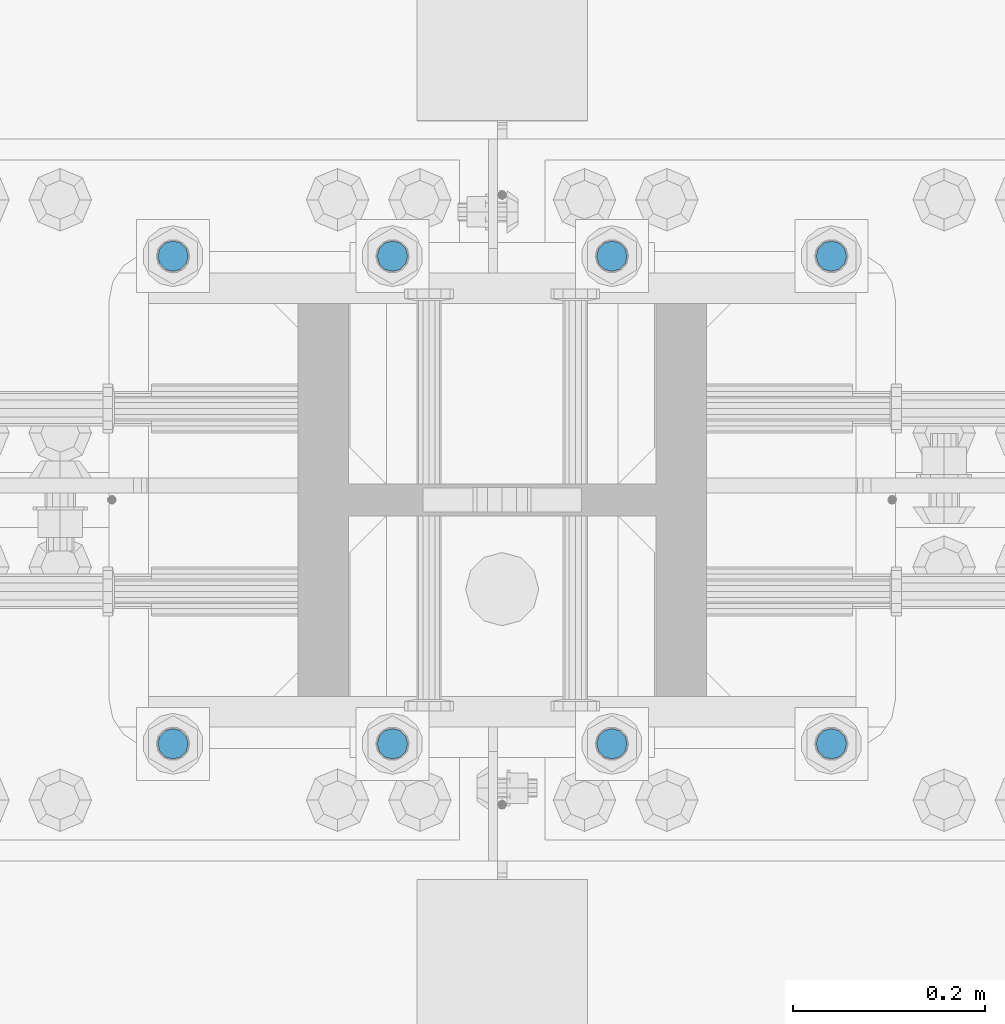
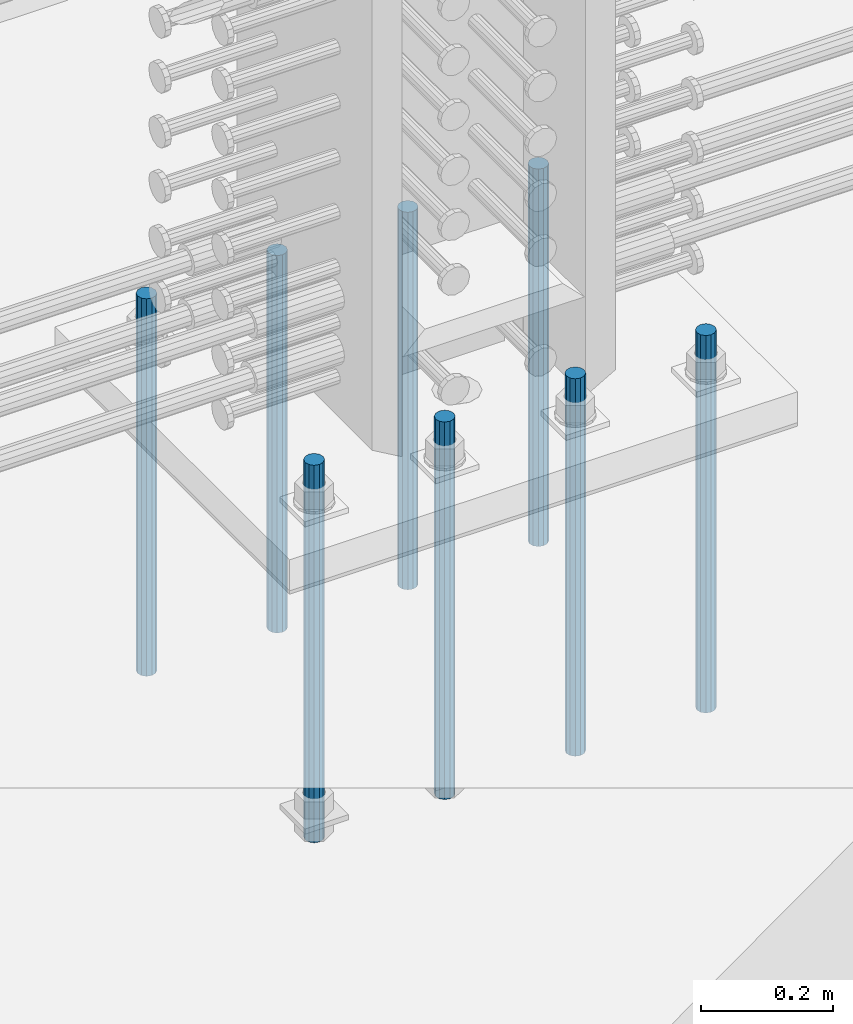
# One storey, part 934 of 1763: 8 columns, 1 element without a shape of its own.
"""IFC2X3 building model written with IfcOpenShell, lengths in millimetres."""

from ifc_helpers import new_model, si_unit, frame, origin_with_axes, place, context, subcontext, project, spatial, faceted_brep, material, type_object, element, aggregate, save


model = new_model("IFC2X3")

# Units and contexts
model_context = context("Model", 3, precision=1e-05, world=origin_with_axes())
body_context = subcontext(model_context, "Body", "Model", "MODEL_VIEW")
ifc_project = project(units=[si_unit("LENGTHUNIT", "METRE", prefix="MILLI"), si_unit("AREAUNIT", "SQUARE_METRE"), si_unit("VOLUMEUNIT", "CUBIC_METRE"), si_unit("MASSUNIT", "GRAM", prefix="KILO"), si_unit("TIMEUNIT", "SECOND"), si_unit("PLANEANGLEUNIT", "RADIAN"), si_unit("SOLIDANGLEUNIT", "STERADIAN"), si_unit("THERMODYNAMICTEMPERATUREUNIT", "DEGREE_CELSIUS"), si_unit("LUMINOUSINTENSITYUNIT", "LUMEN")], contexts=[model_context])

# Site, building, storey
site_placement = place(None, origin_with_axes())
site = spatial("IfcSite", under=ifc_project, at=site_placement, CompositionType="ELEMENT")
building_placement = place(site_placement, origin_with_axes())
building = spatial("IfcBuilding", under=site, at=building_placement, Name="Undefined", CompositionType="ELEMENT")
storey_placement = place(building_placement, origin_with_axes())
storey = spatial("IfcBuildingStorey", under=building, at=storey_placement, Name="Undefined", CompositionType="ELEMENT", Elevation=0.0)

# Assembly, columns
assembly_placement = place(storey_placement, origin_with_axes())
assembly = element("IfcElementAssembly", 1, at=assembly_placement, inside=storey, Name="TEMPLATE", AssemblyPlace="NOTDEFINED", PredefinedType="RIGID_FRAME")
ifc_material = material()
column_type = type_object("IfcColumnType", PredefinedType="NOTDEFINED")
column_1_placement = place(assembly_placement, frame((-49059.5372736986, 203.200000000003, 4000.5), z_axis=(1.0, 0.0, 0.0), x_axis=(0.0, 0.0, -1.0)))
column_1 = element("IfcColumn", 2, at=column_1_placement, type_object=column_type, material=ifc_material, Name="ALL THREADED ROD", context=body_context, shape_type="Brep", body=[
    faceted_brep([(0.0, -15.875, 0.0), (0.0, -13.7481532850798, -7.9375), (698.499, -13.7481532850798, -7.9375), (698.499, -15.875, 0.0), (0.0, -7.9375, -13.748153285078), (698.499, -7.9375, -13.748153285078), (4.91792532185561e-12, 0.0, -15.875), (698.499, 0.0, -15.875), (0.0, 7.9375, -13.748153285078), (698.499, 7.9375, -13.748153285078), (0.0, 13.7481532850798, -7.9375), (698.499, 13.7481532850798, -7.9375), (0.0, 15.875, 0.0), (698.499, 15.875, 0.0), (0.0, 13.7481532850798, 7.9375), (698.499, 13.7481532850798, 7.9375), (0.0, 7.9375, 13.748153285078), (698.499, 7.9375, 13.748153285078), (-1.64518337079051e-12, 0.0, 15.875), (698.499, 0.0, 15.875), (0.0, -7.9375, 13.748153285078), (698.499, -7.9375, 13.748153285078), (0.0, -13.7481532850798, 7.9375), (698.499, -13.7481532850798, 7.9375)], [[[0, 1, 2, 3]], [[1, 4, 5, 2]], [[4, 6, 7, 5]], [[6, 8, 9, 7]], [[8, 10, 11, 9]], [[10, 12, 13, 11]], [[12, 14, 15, 13]], [[14, 16, 17, 15]], [[16, 18, 19, 17]], [[18, 20, 21, 19]], [[20, 22, 23, 21]], [[22, 0, 3, 23]], [[5, 7, 9, 11, 13, 15, 17, 19, 21, 23, 3, 2]], [[22, 20, 18, 16, 14, 12, 10, 8, 6, 4, 1, 0]]]),
])
column_2_placement = place(assembly_placement, frame((-49059.5372736986, 711.200000000003, 4000.5), z_axis=(-1.0, 0.0, 0.0), x_axis=(0.0, 0.0, -1.0)))
column_2 = element("IfcColumn", 3, at=column_2_placement, type_object=column_type, material=ifc_material, Name="ALL THREADED ROD", context=body_context, shape_type="Brep", body=[
    faceted_brep([(0.0, -15.875, 0.0), (0.0, -13.7481532850798, -7.9375), (698.499, -13.7481532850798, -7.9375), (698.499, -15.875, 0.0), (0.0, -7.9375, -13.748153285078), (698.499, -7.9375, -13.748153285078), (4.91792532185561e-12, 0.0, -15.875), (698.499, 0.0, -15.875), (0.0, 7.9375, -13.748153285078), (698.499, 7.9375, -13.748153285078), (0.0, 13.7481532850798, -7.9375), (698.499, 13.7481532850798, -7.9375), (0.0, 15.875, 0.0), (698.499, 15.875, 0.0), (0.0, 13.7481532850798, 7.9375), (698.499, 13.7481532850798, 7.9375), (0.0, 7.9375, 13.748153285078), (698.499, 7.9375, 13.748153285078), (-1.64518337079051e-12, 0.0, 15.875), (698.499, 0.0, 15.875), (0.0, -7.9375, 13.748153285078), (698.499, -7.9375, 13.748153285078), (0.0, -13.7481532850798, 7.9375), (698.499, -13.7481532850798, 7.9375)], [[[0, 1, 2, 3]], [[1, 4, 5, 2]], [[4, 6, 7, 5]], [[6, 8, 9, 7]], [[8, 10, 11, 9]], [[10, 12, 13, 11]], [[12, 14, 15, 13]], [[14, 16, 17, 15]], [[16, 18, 19, 17]], [[18, 20, 21, 19]], [[20, 22, 23, 21]], [[22, 0, 3, 23]], [[5, 7, 9, 11, 13, 15, 17, 19, 21, 23, 3, 2]], [[22, 20, 18, 16, 14, 12, 10, 8, 6, 4, 1, 0]]]),
])
column_3_placement = place(assembly_placement, frame((-49288.1372736986, 203.200000000003, 4000.5), z_axis=(1.0, 0.0, 0.0), x_axis=(0.0, 0.0, -1.0)))
column_3 = element("IfcColumn", 4, at=column_3_placement, type_object=column_type, material=ifc_material, Name="ALL THREADED ROD", context=body_context, shape_type="Brep", body=[
    faceted_brep([(0.0, -15.875, 0.0), (0.0, -13.7481532850798, -7.9375), (698.499, -13.7481532850798, -7.9375), (698.499, -15.875, 0.0), (0.0, -7.9375, -13.748153285078), (698.499, -7.9375, -13.748153285078), (4.91792532185561e-12, 0.0, -15.875), (698.499, 0.0, -15.875), (0.0, 7.9375, -13.748153285078), (698.499, 7.9375, -13.748153285078), (0.0, 13.7481532850798, -7.9375), (698.499, 13.7481532850798, -7.9375), (0.0, 15.875, 0.0), (698.499, 15.875, 0.0), (0.0, 13.7481532850798, 7.9375), (698.499, 13.7481532850798, 7.9375), (0.0, 7.9375, 13.748153285078), (698.499, 7.9375, 13.748153285078), (-1.64518337079051e-12, 0.0, 15.875), (698.499, 0.0, 15.875), (0.0, -7.9375, 13.748153285078), (698.499, -7.9375, 13.748153285078), (0.0, -13.7481532850798, 7.9375), (698.499, -13.7481532850798, 7.9375)], [[[0, 1, 2, 3]], [[1, 4, 5, 2]], [[4, 6, 7, 5]], [[6, 8, 9, 7]], [[8, 10, 11, 9]], [[10, 12, 13, 11]], [[12, 14, 15, 13]], [[14, 16, 17, 15]], [[16, 18, 19, 17]], [[18, 20, 21, 19]], [[20, 22, 23, 21]], [[22, 0, 3, 23]], [[5, 7, 9, 11, 13, 15, 17, 19, 21, 23, 3, 2]], [[22, 20, 18, 16, 14, 12, 10, 8, 6, 4, 1, 0]]]),
])
column_4_placement = place(assembly_placement, frame((-49288.1372736986, 711.200000000003, 4000.5), z_axis=(-1.0, 0.0, 0.0), x_axis=(0.0, 0.0, -1.0)))
column_4 = element("IfcColumn", 5, at=column_4_placement, type_object=column_type, material=ifc_material, Name="ALL THREADED ROD", context=body_context, shape_type="Brep", body=[
    faceted_brep([(0.0, -15.875, 0.0), (0.0, -13.7481532850798, -7.9375), (698.499, -13.7481532850798, -7.9375), (698.499, -15.875, 0.0), (0.0, -7.9375, -13.748153285078), (698.499, -7.9375, -13.748153285078), (4.91792532185561e-12, 0.0, -15.875), (698.499, 0.0, -15.875), (0.0, 7.9375, -13.748153285078), (698.499, 7.9375, -13.748153285078), (0.0, 13.7481532850798, -7.9375), (698.499, 13.7481532850798, -7.9375), (0.0, 15.875, 0.0), (698.499, 15.875, 0.0), (0.0, 13.7481532850798, 7.9375), (698.499, 13.7481532850798, 7.9375), (0.0, 7.9375, 13.748153285078), (698.499, 7.9375, 13.748153285078), (-1.64518337079051e-12, 0.0, 15.875), (698.499, 0.0, 15.875), (0.0, -7.9375, 13.748153285078), (698.499, -7.9375, 13.748153285078), (0.0, -13.7481532850798, 7.9375), (698.499, -13.7481532850798, 7.9375)], [[[0, 1, 2, 3]], [[1, 4, 5, 2]], [[4, 6, 7, 5]], [[6, 8, 9, 7]], [[8, 10, 11, 9]], [[10, 12, 13, 11]], [[12, 14, 15, 13]], [[14, 16, 17, 15]], [[16, 18, 19, 17]], [[18, 20, 21, 19]], [[20, 22, 23, 21]], [[22, 0, 3, 23]], [[5, 7, 9, 11, 13, 15, 17, 19, 21, 23, 3, 2]], [[22, 20, 18, 16, 14, 12, 10, 8, 6, 4, 1, 0]]]),
])
column_5_placement = place(assembly_placement, frame((-49516.7372736986, 203.200000000003, 4000.5), z_axis=(1.0, 0.0, 0.0), x_axis=(0.0, 0.0, -1.0)))
column_5 = element("IfcColumn", 6, at=column_5_placement, type_object=column_type, material=ifc_material, Name="ALL THREADED ROD", context=body_context, shape_type="Brep", body=[
    faceted_brep([(0.0, -15.875, 0.0), (0.0, -13.7481532850798, -7.9375), (698.499, -13.7481532850798, -7.9375), (698.499, -15.875, 0.0), (0.0, -7.9375, -13.748153285078), (698.499, -7.9375, -13.748153285078), (4.91792532185561e-12, 0.0, -15.875), (698.499, 0.0, -15.875), (0.0, 7.9375, -13.748153285078), (698.499, 7.9375, -13.748153285078), (0.0, 13.7481532850798, -7.9375), (698.499, 13.7481532850798, -7.9375), (0.0, 15.875, 0.0), (698.499, 15.875, 0.0), (0.0, 13.7481532850798, 7.9375), (698.499, 13.7481532850798, 7.9375), (0.0, 7.9375, 13.748153285078), (698.499, 7.9375, 13.748153285078), (-1.64518337079051e-12, 0.0, 15.875), (698.499, 0.0, 15.875), (0.0, -7.9375, 13.748153285078), (698.499, -7.9375, 13.748153285078), (0.0, -13.7481532850798, 7.9375), (698.499, -13.7481532850798, 7.9375)], [[[0, 1, 2, 3]], [[1, 4, 5, 2]], [[4, 6, 7, 5]], [[6, 8, 9, 7]], [[8, 10, 11, 9]], [[10, 12, 13, 11]], [[12, 14, 15, 13]], [[14, 16, 17, 15]], [[16, 18, 19, 17]], [[18, 20, 21, 19]], [[20, 22, 23, 21]], [[22, 0, 3, 23]], [[5, 7, 9, 11, 13, 15, 17, 19, 21, 23, 3, 2]], [[22, 20, 18, 16, 14, 12, 10, 8, 6, 4, 1, 0]]]),
])
column_6_placement = place(assembly_placement, frame((-49516.7372736986, 711.200000000003, 4000.5), z_axis=(-1.0, 0.0, 0.0), x_axis=(0.0, 0.0, -1.0)))
column_6 = element("IfcColumn", 7, at=column_6_placement, type_object=column_type, material=ifc_material, Name="ALL THREADED ROD", context=body_context, shape_type="Brep", body=[
    faceted_brep([(0.0, -15.875, 0.0), (0.0, -13.7481532850798, -7.9375), (698.499, -13.7481532850798, -7.9375), (698.499, -15.875, 0.0), (0.0, -7.9375, -13.748153285078), (698.499, -7.9375, -13.748153285078), (4.91792532185561e-12, 0.0, -15.875), (698.499, 0.0, -15.875), (0.0, 7.9375, -13.748153285078), (698.499, 7.9375, -13.748153285078), (0.0, 13.7481532850798, -7.9375), (698.499, 13.7481532850798, -7.9375), (0.0, 15.875, 0.0), (698.499, 15.875, 0.0), (0.0, 13.7481532850798, 7.9375), (698.499, 13.7481532850798, 7.9375), (0.0, 7.9375, 13.748153285078), (698.499, 7.9375, 13.748153285078), (-1.64518337079051e-12, 0.0, 15.875), (698.499, 0.0, 15.875), (0.0, -7.9375, 13.748153285078), (698.499, -7.9375, 13.748153285078), (0.0, -13.7481532850798, 7.9375), (698.499, -13.7481532850798, 7.9375)], [[[0, 1, 2, 3]], [[1, 4, 5, 2]], [[4, 6, 7, 5]], [[6, 8, 9, 7]], [[8, 10, 11, 9]], [[10, 12, 13, 11]], [[12, 14, 15, 13]], [[14, 16, 17, 15]], [[16, 18, 19, 17]], [[18, 20, 21, 19]], [[20, 22, 23, 21]], [[22, 0, 3, 23]], [[5, 7, 9, 11, 13, 15, 17, 19, 21, 23, 3, 2]], [[22, 20, 18, 16, 14, 12, 10, 8, 6, 4, 1, 0]]]),
])
column_7_placement = place(assembly_placement, frame((-49745.3372736986, 203.200000000003, 4000.5), z_axis=(1.0, 0.0, 0.0), x_axis=(0.0, 0.0, -1.0)))
column_7 = element("IfcColumn", 8, at=column_7_placement, type_object=column_type, material=ifc_material, Name="ALL THREADED ROD", context=body_context, shape_type="Brep", body=[
    faceted_brep([(0.0, -15.875, 0.0), (0.0, -13.7481532850798, -7.9375), (698.499, -13.7481532850798, -7.9375), (698.499, -15.875, 0.0), (0.0, -7.9375, -13.748153285078), (698.499, -7.9375, -13.748153285078), (4.91792532185561e-12, 0.0, -15.875), (698.499, 0.0, -15.875), (0.0, 7.9375, -13.748153285078), (698.499, 7.9375, -13.748153285078), (0.0, 13.7481532850798, -7.9375), (698.499, 13.7481532850798, -7.9375), (0.0, 15.875, 0.0), (698.499, 15.875, 0.0), (0.0, 13.7481532850798, 7.9375), (698.499, 13.7481532850798, 7.9375), (0.0, 7.9375, 13.748153285078), (698.499, 7.9375, 13.748153285078), (-1.64518337079051e-12, 0.0, 15.875), (698.499, 0.0, 15.875), (0.0, -7.9375, 13.748153285078), (698.499, -7.9375, 13.748153285078), (0.0, -13.7481532850798, 7.9375), (698.499, -13.7481532850798, 7.9375)], [[[0, 1, 2, 3]], [[1, 4, 5, 2]], [[4, 6, 7, 5]], [[6, 8, 9, 7]], [[8, 10, 11, 9]], [[10, 12, 13, 11]], [[12, 14, 15, 13]], [[14, 16, 17, 15]], [[16, 18, 19, 17]], [[18, 20, 21, 19]], [[20, 22, 23, 21]], [[22, 0, 3, 23]], [[5, 7, 9, 11, 13, 15, 17, 19, 21, 23, 3, 2]], [[22, 20, 18, 16, 14, 12, 10, 8, 6, 4, 1, 0]]]),
])
column_8_placement = place(assembly_placement, frame((-49745.3372736986, 711.200000000003, 4000.5), z_axis=(-1.0, 0.0, 0.0), x_axis=(0.0, 0.0, -1.0)))
column_8 = element("IfcColumn", 9, at=column_8_placement, type_object=column_type, material=ifc_material, Name="ALL THREADED ROD", context=body_context, shape_type="Brep", body=[
    faceted_brep([(0.0, -15.875, 0.0), (0.0, -13.7481532850798, -7.9375), (698.499, -13.7481532850798, -7.9375), (698.499, -15.875, 0.0), (0.0, -7.9375, -13.748153285078), (698.499, -7.9375, -13.748153285078), (4.91792532185561e-12, 0.0, -15.875), (698.499, 0.0, -15.875), (0.0, 7.9375, -13.748153285078), (698.499, 7.9375, -13.748153285078), (0.0, 13.7481532850798, -7.9375), (698.499, 13.7481532850798, -7.9375), (0.0, 15.875, 0.0), (698.499, 15.875, 0.0), (0.0, 13.7481532850798, 7.9375), (698.499, 13.7481532850798, 7.9375), (0.0, 7.9375, 13.748153285078), (698.499, 7.9375, 13.748153285078), (-1.64518337079051e-12, 0.0, 15.875), (698.499, 0.0, 15.875), (0.0, -7.9375, 13.748153285078), (698.499, -7.9375, 13.748153285078), (0.0, -13.7481532850798, 7.9375), (698.499, -13.7481532850798, 7.9375)], [[[0, 1, 2, 3]], [[1, 4, 5, 2]], [[4, 6, 7, 5]], [[6, 8, 9, 7]], [[8, 10, 11, 9]], [[10, 12, 13, 11]], [[12, 14, 15, 13]], [[14, 16, 17, 15]], [[16, 18, 19, 17]], [[18, 20, 21, 19]], [[20, 22, 23, 21]], [[22, 0, 3, 23]], [[5, 7, 9, 11, 13, 15, 17, 19, 21, 23, 3, 2]], [[22, 20, 18, 16, 14, 12, 10, 8, 6, 4, 1, 0]]]),
])
aggregate(assembly, [column_1, column_2, column_3, column_4, column_5, column_6, column_7, column_8])

save(model, "model.ifc")
